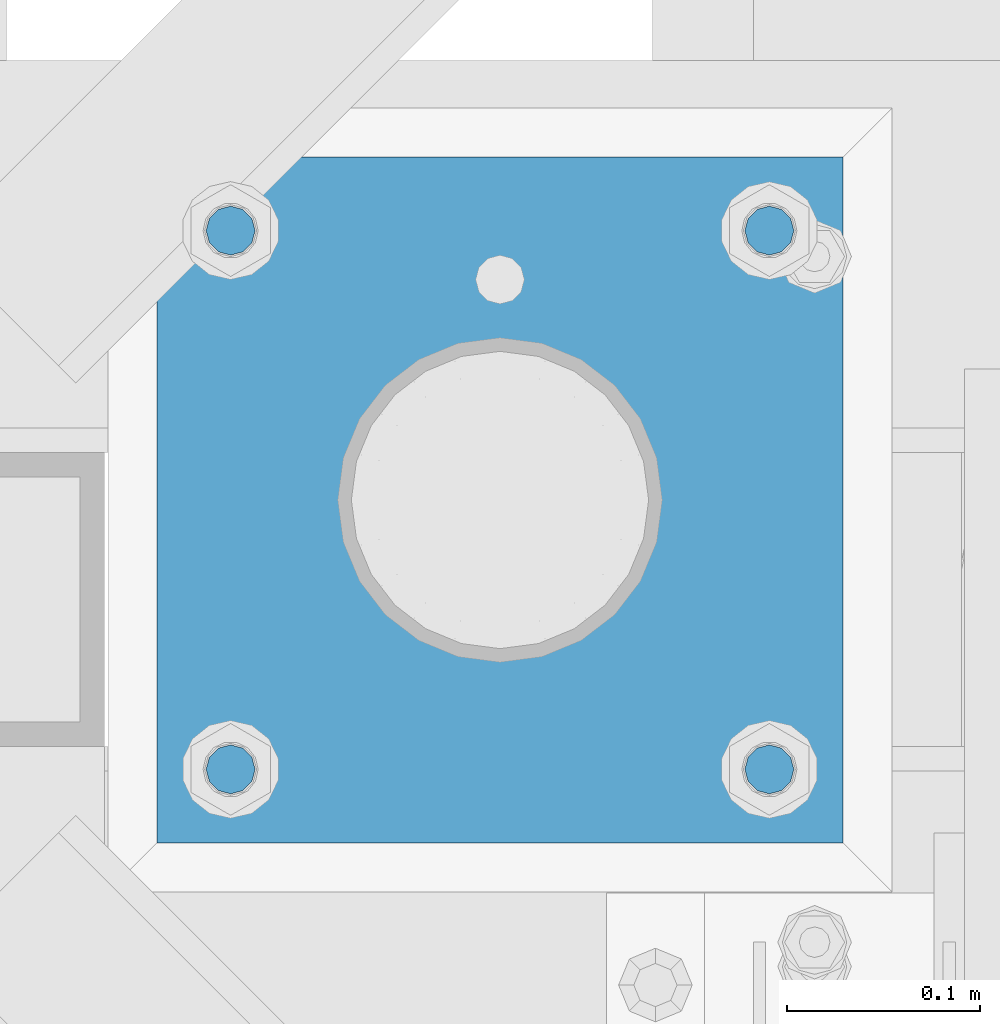
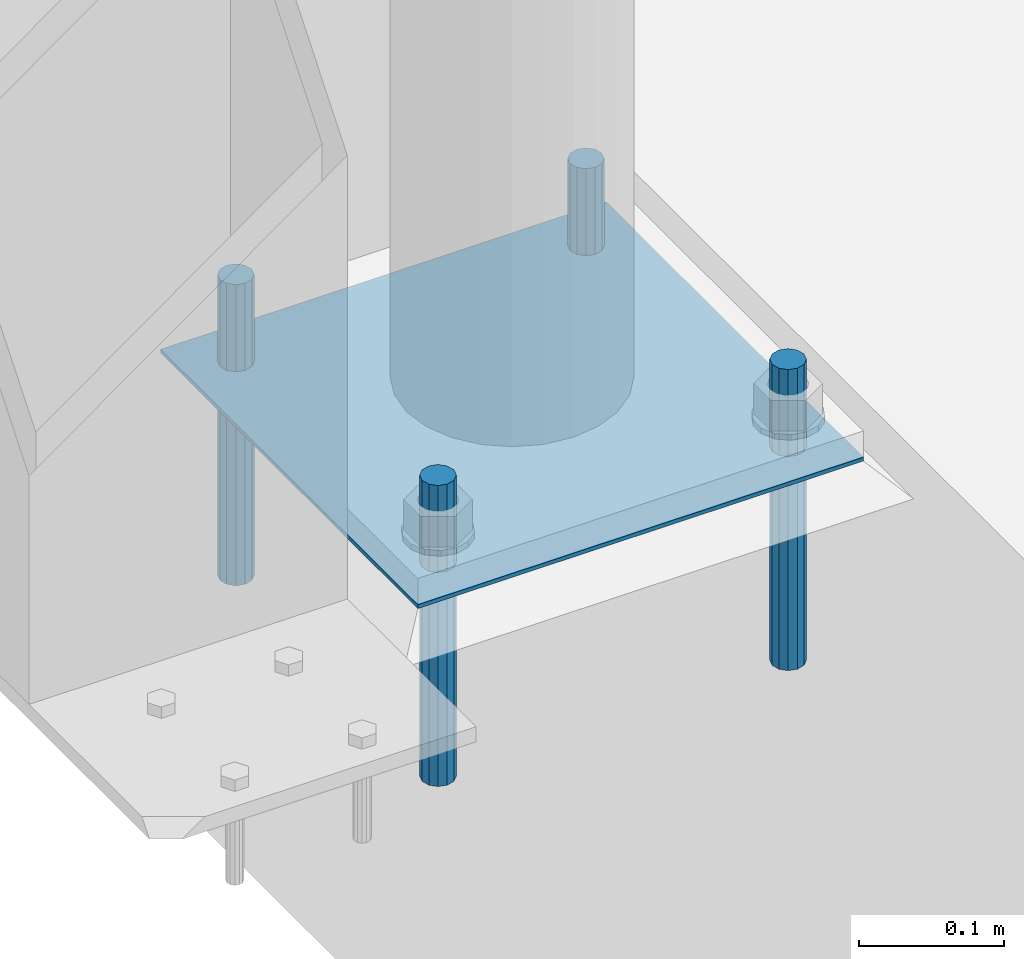
# One storey, part 2027 of 3843: 5 beams, 1 element without a shape of its own.
"""IFC2X3 building model written with IfcOpenShell, lengths in millimetres."""

from ifc_helpers import new_model, si_unit, frame, origin_with_axes, place, context, subcontext, project, spatial, faceted_brep, material, type_object, element, aggregate, save


model = new_model("IFC2X3")

# Units and contexts
model_context = context("Model", 3, precision=1e-05, world=origin_with_axes())
body_context = subcontext(model_context, "Body", "Model", "MODEL_VIEW")
ifc_project = project(units=[si_unit("LENGTHUNIT", "METRE", prefix="MILLI"), si_unit("AREAUNIT", "SQUARE_METRE"), si_unit("VOLUMEUNIT", "CUBIC_METRE"), si_unit("MASSUNIT", "GRAM", prefix="KILO"), si_unit("TIMEUNIT", "SECOND"), si_unit("PLANEANGLEUNIT", "RADIAN"), si_unit("SOLIDANGLEUNIT", "STERADIAN"), si_unit("THERMODYNAMICTEMPERATUREUNIT", "DEGREE_CELSIUS"), si_unit("LUMINOUSINTENSITYUNIT", "LUMEN")], contexts=[model_context])

# Site, building, storey
site_placement = place(None, origin_with_axes())
site = spatial("IfcSite", under=ifc_project, at=site_placement, CompositionType="ELEMENT")
building_placement = place(site_placement, origin_with_axes())
building = spatial("IfcBuilding", under=site, at=building_placement, Name="Undefined", CompositionType="ELEMENT")
storey_placement = place(building_placement, origin_with_axes())
storey = spatial("IfcBuildingStorey", under=building, at=storey_placement, Name="Undefined", CompositionType="ELEMENT", Elevation=0.0)

# Assembly, beams
assembly_placement = place(storey_placement, origin_with_axes())
assembly = element("IfcElementAssembly", 1, at=assembly_placement, inside=storey, Name="TEMPLATE", AssemblyPlace="NOTDEFINED", PredefinedType="RIGID_FRAME")
ifc_material_1 = material(Name="STEEL/316 SS")
beam_type_1 = type_object("IfcBeamType", PredefinedType="NOTDEFINED")
beam_1_placement = place(assembly_placement, frame((41969.1014282227, 27127.9153033043, 30581.6), z_axis=(1.0, 0.0, 0.0), x_axis=(0.0, 0.0, -1.0)))
beam_1 = element("IfcBeam", 2, at=beam_1_placement, type_object=beam_type_1, material=ifc_material_1, Name="ANCHOR_ROD", context=body_context, shape_type="Brep", body=[
    faceted_brep([(0.0, -12.6999999999971, 0.0), (0.0, -10.9985226280696, -6.34999999999854), (253.999, -10.9985226280696, -6.34999999999854), (253.999, -12.6999999999971, 0.0), (0.0, -6.35000000000582, -10.9985226280623), (253.999, -6.35000000000582, -10.9985226280623), (0.0, 0.0, -12.6999999999971), (253.999, 0.0, -12.6999999999971), (0.0, 6.35000000000582, -10.9985226280623), (253.999, 6.35000000000582, -10.9985226280623), (0.0, 10.9985226280696, -6.34999999999854), (253.999, 10.9985226280696, -6.34999999999854), (0.0, 12.6999999999971, 0.0), (253.999, 12.6999999999971, 0.0), (0.0, 10.9985226280696, 6.34999999999854), (253.999, 10.9985226280696, 6.34999999999854), (0.0, 6.35000000000582, 10.9985226280623), (253.999, 6.35000000000582, 10.9985226280623), (0.0, 0.0, 12.6999999999971), (253.999, 0.0, 12.6999999999971), (0.0, -6.35000000000582, 10.9985226280623), (253.999, -6.35000000000582, 10.9985226280623), (0.0, -10.9985226280696, 6.34999999999854), (253.999, -10.9985226280696, 6.34999999999854)], [[[0, 1, 2, 3]], [[1, 4, 5, 2]], [[4, 6, 7, 5]], [[6, 8, 9, 7]], [[8, 10, 11, 9]], [[10, 12, 13, 11]], [[12, 14, 15, 13]], [[14, 16, 17, 15]], [[16, 18, 19, 17]], [[18, 20, 21, 19]], [[20, 22, 23, 21]], [[22, 0, 3, 23]], [[5, 7, 9, 11, 13, 15, 17, 19, 21, 23, 3, 2]], [[22, 20, 18, 16, 14, 12, 10, 8, 6, 4, 1, 0]]]),
])
beam_2_placement = place(assembly_placement, frame((41969.1014282227, 27407.3153033043, 30581.6), z_axis=(-1.0, 0.0, 0.0), x_axis=(0.0, 0.0, -1.0)))
beam_2 = element("IfcBeam", 3, at=beam_2_placement, type_object=beam_type_1, material=ifc_material_1, Name="ANCHOR_ROD", context=body_context, shape_type="Brep", body=[
    faceted_brep([(0.0, -12.6999999999971, 0.0), (0.0, -10.9985226280696, -6.34999999999854), (253.999, -10.9985226280696, -6.34999999999854), (253.999, -12.6999999999971, 0.0), (0.0, -6.35000000000582, -10.9985226280623), (253.999, -6.35000000000582, -10.9985226280623), (0.0, 0.0, -12.6999999999971), (253.999, 0.0, -12.6999999999971), (0.0, 6.35000000000582, -10.9985226280623), (253.999, 6.35000000000582, -10.9985226280623), (0.0, 10.9985226280696, -6.34999999999854), (253.999, 10.9985226280696, -6.34999999999854), (0.0, 12.6999999999971, 0.0), (253.999, 12.6999999999971, 0.0), (0.0, 10.9985226280696, 6.34999999999854), (253.999, 10.9985226280696, 6.34999999999854), (0.0, 6.35000000000582, 10.9985226280623), (253.999, 6.35000000000582, 10.9985226280623), (0.0, 0.0, 12.6999999999971), (253.999, 0.0, 12.6999999999971), (0.0, -6.35000000000582, 10.9985226280623), (253.999, -6.35000000000582, 10.9985226280623), (0.0, -10.9985226280696, 6.34999999999854), (253.999, -10.9985226280696, 6.34999999999854)], [[[0, 1, 2, 3]], [[1, 4, 5, 2]], [[4, 6, 7, 5]], [[6, 8, 9, 7]], [[8, 10, 11, 9]], [[10, 12, 13, 11]], [[12, 14, 15, 13]], [[14, 16, 17, 15]], [[16, 18, 19, 17]], [[18, 20, 21, 19]], [[20, 22, 23, 21]], [[22, 0, 3, 23]], [[5, 7, 9, 11, 13, 15, 17, 19, 21, 23, 3, 2]], [[22, 20, 18, 16, 14, 12, 10, 8, 6, 4, 1, 0]]]),
])
beam_3_placement = place(assembly_placement, frame((41689.7014282227, 27127.9153033043, 30581.6), z_axis=(1.0, 0.0, 0.0), x_axis=(0.0, 0.0, -1.0)))
beam_3 = element("IfcBeam", 4, at=beam_3_placement, type_object=beam_type_1, material=ifc_material_1, Name="ANCHOR_ROD", context=body_context, shape_type="Brep", body=[
    faceted_brep([(0.0, -12.6999999999971, 0.0), (0.0, -10.9985226280696, -6.34999999999854), (253.999, -10.9985226280696, -6.34999999999854), (253.999, -12.6999999999971, 0.0), (0.0, -6.35000000000582, -10.9985226280623), (253.999, -6.35000000000582, -10.9985226280623), (0.0, 0.0, -12.6999999999971), (253.999, 0.0, -12.6999999999971), (0.0, 6.35000000000582, -10.9985226280623), (253.999, 6.35000000000582, -10.9985226280623), (0.0, 10.9985226280696, -6.34999999999854), (253.999, 10.9985226280696, -6.34999999999854), (0.0, 12.6999999999971, 0.0), (253.999, 12.6999999999971, 0.0), (0.0, 10.9985226280696, 6.34999999999854), (253.999, 10.9985226280696, 6.34999999999854), (0.0, 6.35000000000582, 10.9985226280623), (253.999, 6.35000000000582, 10.9985226280623), (0.0, 0.0, 12.6999999999971), (253.999, 0.0, 12.6999999999971), (0.0, -6.35000000000582, 10.9985226280623), (253.999, -6.35000000000582, 10.9985226280623), (0.0, -10.9985226280696, 6.34999999999854), (253.999, -10.9985226280696, 6.34999999999854)], [[[0, 1, 2, 3]], [[1, 4, 5, 2]], [[4, 6, 7, 5]], [[6, 8, 9, 7]], [[8, 10, 11, 9]], [[10, 12, 13, 11]], [[12, 14, 15, 13]], [[14, 16, 17, 15]], [[16, 18, 19, 17]], [[18, 20, 21, 19]], [[20, 22, 23, 21]], [[22, 0, 3, 23]], [[5, 7, 9, 11, 13, 15, 17, 19, 21, 23, 3, 2]], [[22, 20, 18, 16, 14, 12, 10, 8, 6, 4, 1, 0]]]),
])
beam_4_placement = place(assembly_placement, frame((41689.7014282227, 27407.3153033043, 30581.6), z_axis=(-1.0, 0.0, 0.0), x_axis=(0.0, 0.0, -1.0)))
beam_4 = element("IfcBeam", 5, at=beam_4_placement, type_object=beam_type_1, material=ifc_material_1, Name="ANCHOR_ROD", context=body_context, shape_type="Brep", body=[
    faceted_brep([(0.0, -12.6999999999971, 0.0), (0.0, -10.9985226280696, -6.34999999999854), (253.999, -10.9985226280696, -6.34999999999854), (253.999, -12.6999999999971, 0.0), (0.0, -6.35000000000582, -10.9985226280623), (253.999, -6.35000000000582, -10.9985226280623), (0.0, 0.0, -12.6999999999971), (253.999, 0.0, -12.6999999999971), (0.0, 6.35000000000582, -10.9985226280623), (253.999, 6.35000000000582, -10.9985226280623), (0.0, 10.9985226280696, -6.34999999999854), (253.999, 10.9985226280696, -6.34999999999854), (0.0, 12.6999999999971, 0.0), (253.999, 12.6999999999971, 0.0), (0.0, 10.9985226280696, 6.34999999999854), (253.999, 10.9985226280696, 6.34999999999854), (0.0, 6.35000000000582, 10.9985226280623), (253.999, 6.35000000000582, 10.9985226280623), (0.0, 0.0, 12.6999999999971), (253.999, 0.0, 12.6999999999971), (0.0, -6.35000000000582, 10.9985226280623), (253.999, -6.35000000000582, 10.9985226280623), (0.0, -10.9985226280696, 6.34999999999854), (253.999, -10.9985226280696, 6.34999999999854)], [[[0, 1, 2, 3]], [[1, 4, 5, 2]], [[4, 6, 7, 5]], [[6, 8, 9, 7]], [[8, 10, 11, 9]], [[10, 12, 13, 11]], [[12, 14, 15, 13]], [[14, 16, 17, 15]], [[16, 18, 19, 17]], [[18, 20, 21, 19]], [[20, 22, 23, 21]], [[22, 0, 3, 23]], [[5, 7, 9, 11, 13, 15, 17, 19, 21, 23, 3, 2]], [[22, 20, 18, 16, 14, 12, 10, 8, 6, 4, 1, 0]]]),
])
ifc_material_2 = material(Name="STEEL/A36")
beam_type_2 = type_object("IfcBeamType", PredefinedType="NOTDEFINED")
beam_5_placement = place(assembly_placement, frame((42007.2014282227, 27267.6153033043, 30506.9875), z_axis=(0.0, -1.0, 0.0), x_axis=(-1.0, 0.0, 0.0)))
beam_5 = element("IfcBeam", 6, at=beam_5_placement, type_object=beam_type_2, material=ifc_material_2, Name="TEMPLATE", context=body_context, shape_type="Brep", body=[
    faceted_brep([(0.0, 1.58750000000146, -177.800000000003), (0.0, 1.58750000000146, 177.800000000003), (355.600000000006, 1.58750000000146, 177.800000000003), (355.600000000006, 1.58750000000146, -177.800000000003), (0.0, -1.58750000000146, 177.800000000003), (355.600000000006, -1.58750000000146, 177.800000000003), (0.0, -1.58750000000146, -177.800000000003), (355.600000000006, -1.58750000000146, -177.800000000003)], [[[0, 1, 2, 3]], [[1, 4, 5, 2]], [[4, 6, 7, 5]], [[6, 0, 3, 7]], [[5, 7, 3, 2]], [[6, 4, 1, 0]]]),
])
aggregate(assembly, [beam_1, beam_2, beam_3, beam_4, beam_5])

save(model, "model.ifc")
